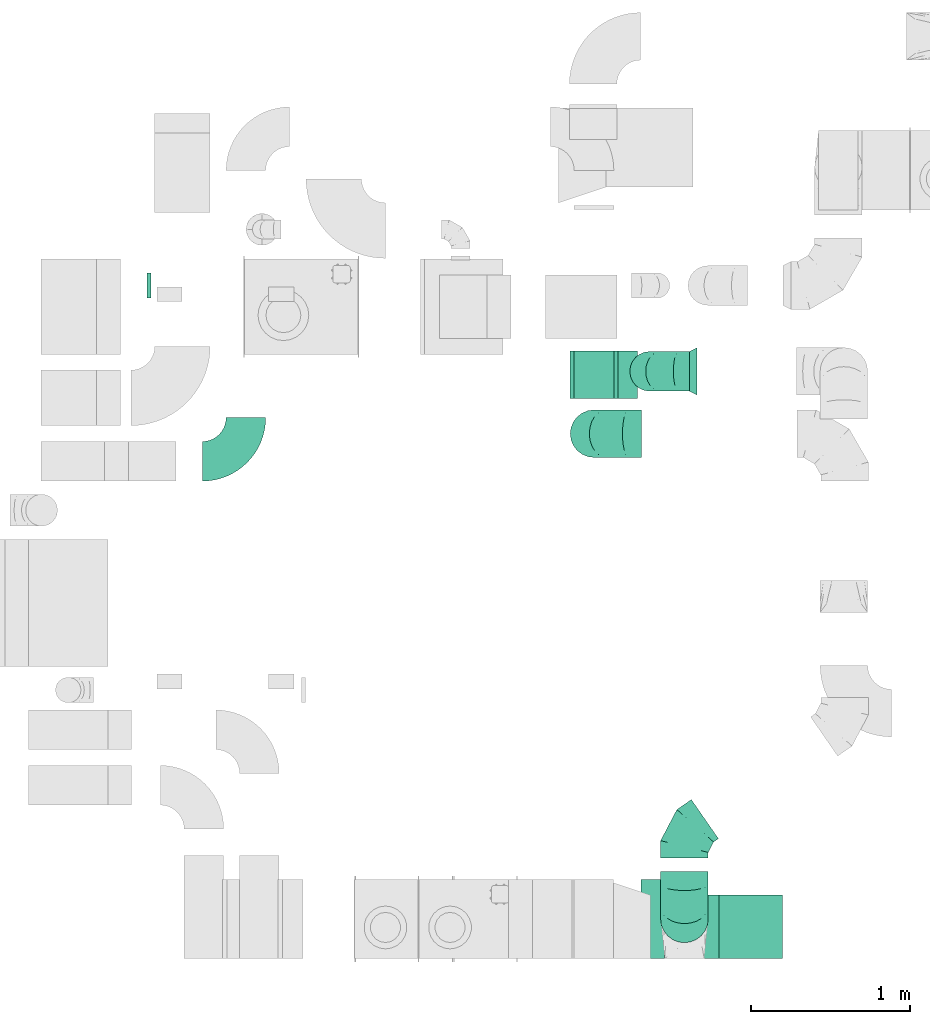
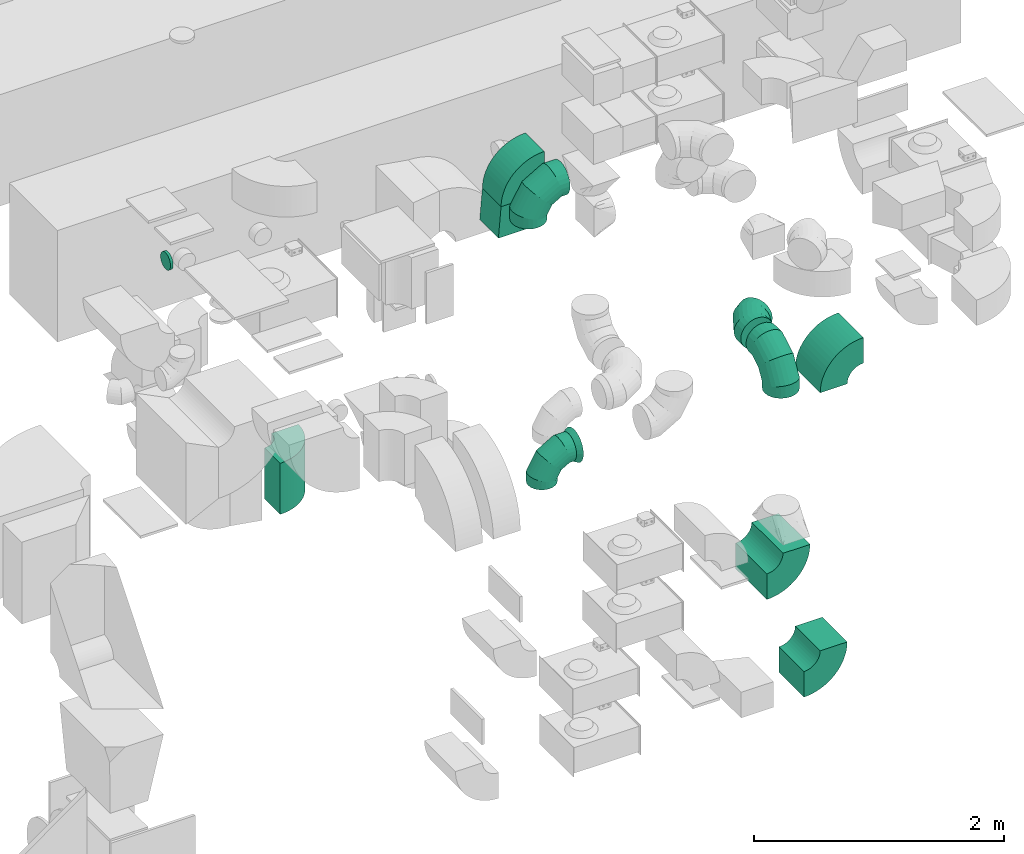
# One storey, part 9 of 59: 12 flow fittings.
"""IFC2X3 building model written with IfcOpenShell, lengths in millimetres."""

from ifc_helpers import new_model, entity, si_unit, converted_unit, derived_unit, direction, frame, frame_2d, origin, origin_2d_with_axis, place, context, subcontext, project, spatial, polyline, circle_curve, parameter, trimmed, segment, composite_curve, circle, outline, extrude, faceted_brep, source, transform, mapped, material, type_object, type_shapes, element, save


model = new_model("IFC2X3")

# Units and contexts
model_context = context("Model", 3, precision=0.01, world=origin(), true_north=direction((6.12303176911189e-17, 1.0)))
body_context = subcontext(model_context, "Body", "Model", "MODEL_VIEW")
ifc_project = project(units=[si_unit("LENGTHUNIT", "METRE", prefix="MILLI"), si_unit("AREAUNIT", "SQUARE_METRE"), si_unit("VOLUMEUNIT", "CUBIC_METRE"), converted_unit("PLANEANGLEUNIT", "DEGREE", entity("IfcRatioMeasure", 0.0174532925199433), si_unit("PLANEANGLEUNIT", "RADIAN"), dimensions=[0, 0, 0, 0, 0, 0, 0]), si_unit("MASSUNIT", "GRAM", prefix="KILO"), derived_unit("MASSDENSITYUNIT", [(si_unit("MASSUNIT", "GRAM", prefix="KILO"), 1), (si_unit("LENGTHUNIT", "METRE"), -3)]), derived_unit("MOMENTOFINERTIAUNIT", [(si_unit("LENGTHUNIT", "METRE"), 4)]), si_unit("TIMEUNIT", "SECOND"), si_unit("FREQUENCYUNIT", "HERTZ"), si_unit("THERMODYNAMICTEMPERATUREUNIT", "DEGREE_CELSIUS"), derived_unit("THERMALTRANSMITTANCEUNIT", [(si_unit("MASSUNIT", "GRAM", prefix="KILO"), 1), (si_unit("THERMODYNAMICTEMPERATUREUNIT", "KELVIN"), -1), (si_unit("TIMEUNIT", "SECOND"), -3)]), derived_unit("VOLUMETRICFLOWRATEUNIT", [(si_unit("LENGTHUNIT", "METRE"), 3), (si_unit("TIMEUNIT", "SECOND"), -1)]), derived_unit("MASSFLOWRATEUNIT", [(si_unit("MASSUNIT", "GRAM", prefix="KILO"), 1), (si_unit("TIMEUNIT", "SECOND"), -1)]), derived_unit("ROTATIONALFREQUENCYUNIT", [(si_unit("TIMEUNIT", "SECOND"), -1)]), si_unit("ELECTRICCURRENTUNIT", "AMPERE"), si_unit("ELECTRICVOLTAGEUNIT", "VOLT"), si_unit("POWERUNIT", "WATT"), si_unit("FORCEUNIT", "NEWTON", prefix="KILO"), si_unit("ILLUMINANCEUNIT", "LUX"), si_unit("LUMINOUSFLUXUNIT", "LUMEN"), si_unit("LUMINOUSINTENSITYUNIT", "CANDELA"), derived_unit("USERDEFINED", [(si_unit("MASSUNIT", "GRAM", prefix="KILO"), -1), (si_unit("LENGTHUNIT", "METRE"), -2), (si_unit("TIMEUNIT", "SECOND"), 3), (si_unit("LUMINOUSFLUXUNIT", "LUMEN"), 1)]), derived_unit("LINEARVELOCITYUNIT", [(si_unit("LENGTHUNIT", "METRE"), 1), (si_unit("TIMEUNIT", "SECOND"), -1)]), si_unit("PRESSUREUNIT", "PASCAL"), derived_unit("USERDEFINED", [(si_unit("LENGTHUNIT", "METRE"), -2), (si_unit("MASSUNIT", "GRAM", prefix="KILO"), 1), (si_unit("TIMEUNIT", "SECOND"), -2)]), derived_unit("LINEARFORCEUNIT", [(si_unit("MASSUNIT", "GRAM", prefix="KILO"), 1), (si_unit("LENGTHUNIT", "METRE"), 1), (si_unit("TIMEUNIT", "SECOND"), -2), (si_unit("LENGTHUNIT", "METRE"), -1)]), derived_unit("PLANARFORCEUNIT", [(si_unit("MASSUNIT", "GRAM", prefix="KILO"), 1), (si_unit("LENGTHUNIT", "METRE"), 1), (si_unit("TIMEUNIT", "SECOND"), -2), (si_unit("LENGTHUNIT", "METRE"), -2)])], contexts=[model_context])

# Site, building, storey
site_placement = place(None, origin())
site = spatial("IfcSite", under=ifc_project, at=site_placement, CompositionType="ELEMENT")
building_placement = place(site_placement, origin())
building = spatial("IfcBuilding", under=site, at=building_placement, CompositionType="ELEMENT")
storey_placement = place(building_placement, frame((0.0, 0.0, 28200.0)))
storey = spatial("IfcBuildingStorey", under=building, at=storey_placement, CompositionType="ELEMENT", Elevation=28200.0)

# Flow fittings
ifc_material = material()
duct_fitting_type_1 = type_object("IfcDuctFittingType", PredefinedType="NOTDEFINED", material=ifc_material)
shared_shape_1 = source(origin(), body_context, "Body", "SweptSolid", [
    extrude(circle(Radius=79.9999999999994, at=origin_2d_with_axis()), frame((0.0, 0.0, 0.0), z_axis=(1.0, 0.0, 0.0), x_axis=(0.0, 1.0, 0.0)), (0.0, 0.0, 1.0), 25.0000000000018),
])
type_shapes(duct_fitting_type_1, [shared_shape_1])
flow_fitting_1_placement = place(storey_placement, frame((28347.12, 12178.65, 3205.01), z_axis=(0.0, 0.0, 1.0), x_axis=(-1.0, 0.0, 0.0)))
element("IfcFlowFitting", 1, at=flow_fitting_1_placement, inside=storey, type_object=duct_fitting_type_1, material=ifc_material, context=body_context, shape_type="MappedRepresentation", body=[
    mapped(shared_shape_1, transform((0.0, 0.0, 0.0), scale=1.0)),
])
duct_fitting_type_2 = type_object("IfcDuctFittingType", PredefinedType="NOTDEFINED", material=ifc_material)
shared_shape_2 = source(origin(), body_context, "Body", "SweptSolid", [
    extrude(outline(polyline([(-125.0, -150.0), (125.0, -150.0), (150.0, 150.0), (-150.0, 150.0), (-125.0, -150.0)])), frame((150.0, -150.0, 0.0), z_axis=(0.0, 1.0, 0.0), x_axis=(0.0, 0.0, 1.0)), (0.0, 0.0, 1.0), 300.0),
])
type_shapes(duct_fitting_type_2, [shared_shape_2])
flow_fitting_2_placement = place(storey_placement, frame((31140.08, 11614.96, 3225.0), z_axis=(1.0, 0.0, 0.0), x_axis=(0.0, 0.0, -1.0)))
element("IfcFlowFitting", 2, at=flow_fitting_2_placement, inside=storey, type_object=duct_fitting_type_2, material=ifc_material, context=body_context, shape_type="MappedRepresentation", body=[
    mapped(shared_shape_2, transform((0.0, 0.0, 0.0), scale=1.0)),
])
duct_fitting_type_3 = type_object("IfcDuctFittingType", PredefinedType="NOTDEFINED", material=ifc_material)
shared_shape_3 = source(origin(), body_context, "Body", "Brep", [
    faceted_brep([(-250.0, 0.0, -125.0), (-250.0, -32.35, -120.74), (-250.0, -62.5, -108.25), (-250.0, -88.39, -88.39), (-250.0, -108.25, -62.5), (-250.0, -120.74, -32.35), (-250.0, -125.0, 0.0), (-250.0, -120.74, 32.35), (-250.0, -108.25, 62.5), (-250.0, -88.39, 88.39), (-250.0, -62.5, 108.25), (-250.0, -32.35, 120.74), (-250.0, 0.0, 125.0), (-250.0, 32.35, 120.74), (-250.0, 62.5, 108.25), (-250.0, 88.39, 88.39), (-250.0, 108.25, 62.5), (-250.0, 120.74, 32.35), (-250.0, 125.0, 0.0), (-250.0, 120.74, -32.35), (-250.0, 108.25, -62.5), (-250.0, 88.39, -88.39), (-250.0, 62.5, -108.25), (-250.0, 32.35, -120.74), (-191.68, 32.35, 120.74), (-199.76, 62.5, 108.25), (-183.01, 0.0, 125.0), (-206.7, 88.39, 88.39), (-215.37, 120.74, 32.35), (-216.51, 125.0, 0.0), (-212.02, 108.25, 62.5), (-212.02, 108.25, -62.5), (-206.7, 88.39, -88.39), (-215.37, 120.74, -32.35), (-191.68, 32.35, -120.74), (-183.01, 0.0, -125.0), (-199.76, 62.5, -108.25), (-174.34, -32.35, -120.74), (-166.27, -62.5, -108.25), (-159.33, -88.39, -88.39), (-154.01, -108.25, -62.5), (-150.66, -120.74, -32.35), (-149.52, -125.0, 0.0), (-150.66, -120.74, 32.35), (-154.01, -108.25, 62.5), (-159.33, -88.39, 88.39), (-166.27, -62.5, 108.25), (-174.34, -32.35, 120.74), (-90.67, 90.67, 120.74), (-112.74, 112.74, 108.25), (-66.99, 66.99, 125.0), (-131.69, 131.69, 88.39), (-146.23, 146.23, 62.5), (-155.38, 155.38, 32.35), (-158.49, 158.49, 0.0), (-155.38, 155.38, -32.35), (-146.23, 146.23, -62.5), (-131.69, 131.69, -88.39), (-90.67, 90.67, -120.74), (-66.99, 66.99, -125.0), (-112.74, 112.74, -108.25), (-43.3, 43.3, -120.74), (-21.23, 21.23, -108.25), (-2.28, 2.28, -88.39), (12.26, -12.26, -62.5), (21.4, -21.4, -32.35), (24.52, -24.52, 0.0), (21.4, -21.4, 32.35), (12.26, -12.26, 62.5), (-2.28, 2.28, 88.39), (-21.23, 21.23, 108.25), (-43.3, 43.3, 120.74), (-32.35, 191.68, 120.74), (-62.5, 199.76, 108.25), (0.0, 183.01, 125.0), (-88.39, 206.7, 88.39), (-108.25, 212.02, 62.5), (-120.74, 215.37, 32.35), (-125.0, 216.51, 0.0), (-120.74, 215.37, -32.35), (-108.25, 212.02, -62.5), (-88.39, 206.7, -88.39), (-32.35, 191.68, -120.74), (0.0, 183.01, -125.0), (-62.5, 199.76, -108.25), (32.35, 174.34, -120.74), (62.5, 166.27, -108.25), (88.39, 159.33, -88.39), (108.25, 154.01, -62.5), (120.74, 150.66, -32.35), (125.0, 149.52, 0.0), (120.74, 150.66, 32.35), (108.25, 154.01, 62.5), (88.39, 159.33, 88.39), (62.5, 166.27, 108.25), (32.35, 174.34, 120.74), (-32.35, 250.0, -120.74), (-62.5, 250.0, -108.25), (-88.39, 250.0, -88.39), (-108.25, 250.0, -62.5), (-120.74, 250.0, -32.35), (-125.0, 250.0, 0.0), (-120.74, 250.0, 32.35), (-108.25, 250.0, 62.5), (-88.39, 250.0, 88.39), (-62.5, 250.0, 108.25), (-32.35, 250.0, 120.74), (0.0, 250.0, 125.0), (32.35, 250.0, 120.74), (62.5, 250.0, 108.25), (88.39, 250.0, 88.39), (108.25, 250.0, 62.5), (120.74, 250.0, 32.35), (125.0, 250.0, 0.0), (120.74, 250.0, -32.35), (108.25, 250.0, -62.5), (88.39, 250.0, -88.39), (62.5, 250.0, -108.25), (32.35, 250.0, -120.74), (0.0, 250.0, -125.0)], [[[0, 1, 2, 3, 4, 5, 6, 7, 8, 9, 10, 11, 12, 13, 14, 15, 16, 17, 18, 19, 20, 21, 22, 23]], [[24, 25, 14, 13]], [[26, 24, 13, 12]], [[14, 25, 27, 15]], [[28, 29, 18, 17]], [[30, 28, 17, 16]], [[15, 27, 30, 16]], [[20, 31, 32, 21]], [[33, 31, 20, 19]], [[18, 29, 33, 19]], [[34, 35, 0, 23]], [[36, 34, 23, 22]], [[21, 32, 36, 22]], [[1, 0, 35, 37]], [[2, 1, 37, 38]], [[38, 39, 3, 2]], [[5, 4, 40, 41]], [[6, 5, 41, 42]], [[39, 40, 4, 3]], [[6, 42, 43, 7]], [[7, 43, 44, 8]], [[8, 44, 45, 9]], [[9, 45, 46, 10]], [[10, 46, 47, 11]], [[26, 12, 11, 47]], [[48, 49, 25, 24]], [[50, 48, 24, 26]], [[27, 25, 49, 51]], [[52, 53, 28, 30]], [[51, 52, 30, 27]], [[29, 28, 53, 54]], [[55, 56, 31, 33]], [[54, 55, 33, 29]], [[32, 31, 56, 57]], [[58, 59, 35, 34]], [[60, 58, 34, 36]], [[57, 60, 36, 32]], [[37, 35, 59, 61]], [[38, 37, 61, 62]], [[39, 38, 62, 63]], [[41, 40, 64, 65]], [[42, 41, 65, 66]], [[63, 64, 40, 39]], [[43, 42, 66, 67]], [[44, 43, 67, 68]], [[68, 69, 45, 44]], [[46, 45, 69, 70]], [[47, 46, 70, 71]], [[26, 47, 71, 50]], [[72, 73, 49, 48]], [[74, 72, 48, 50]], [[51, 49, 73, 75]], [[76, 77, 53, 52]], [[75, 76, 52, 51]], [[54, 53, 77, 78]], [[79, 80, 56, 55]], [[78, 79, 55, 54]], [[57, 56, 80, 81]], [[82, 83, 59, 58]], [[84, 82, 58, 60]], [[81, 84, 60, 57]], [[61, 59, 83, 85]], [[62, 61, 85, 86]], [[63, 62, 86, 87]], [[65, 64, 88, 89]], [[66, 65, 89, 90]], [[87, 88, 64, 63]], [[67, 66, 90, 91]], [[68, 67, 91, 92]], [[92, 93, 69, 68]], [[70, 69, 93, 94]], [[71, 70, 94, 95]], [[50, 71, 95, 74]], [[96, 97, 98, 99, 100, 101, 102, 103, 104, 105, 106, 107, 108, 109, 110, 111, 112, 113, 114, 115, 116, 117, 118, 119]], [[72, 74, 107, 106]], [[73, 72, 106, 105]], [[75, 73, 105, 104]], [[77, 76, 103, 102]], [[78, 77, 102, 101]], [[75, 104, 103, 76]], [[78, 101, 100, 79]], [[79, 100, 99, 80]], [[80, 99, 98, 81]], [[84, 97, 96, 82]], [[82, 96, 119, 83]], [[84, 81, 98, 97]], [[83, 119, 118, 85]], [[85, 118, 117, 86]], [[116, 87, 86, 117]], [[88, 115, 114, 89]], [[89, 114, 113, 90]], [[115, 88, 87, 116]], [[91, 90, 113, 112]], [[92, 91, 112, 111]], [[111, 110, 93, 92]], [[95, 94, 109, 108]], [[74, 95, 108, 107]], [[110, 109, 94, 93]]]),
])
type_shapes(duct_fitting_type_3, [shared_shape_3])
flow_fitting_3_placement = place(storey_placement, frame((31490.77, 11637.41, 520.0), z_axis=(0.0, -1.0, 0.0), x_axis=(-1.0, 0.0, 0.0)))
element("IfcFlowFitting", 3, at=flow_fitting_3_placement, inside=storey, type_object=duct_fitting_type_3, material=ifc_material, context=body_context, shape_type="MappedRepresentation", body=[
    mapped(shared_shape_3, transform((0.0, 0.0, 0.0), scale=1.0)),
])
duct_fitting_type_4 = type_object("IfcDuctFittingType", PredefinedType="NOTDEFINED", material=ifc_material)
shared_shape_4 = source(origin(), body_context, "Body", "Brep", [
    faceted_brep([(-300.0, 0.0, -150.0), (-300.0, -38.82, -144.89), (-300.0, -75.0, -129.9), (-300.0, -106.07, -106.07), (-300.0, -129.9, -75.0), (-300.0, -144.89, -38.82), (-300.0, -150.0, 0.0), (-300.0, -144.89, 38.82), (-300.0, -129.9, 75.0), (-300.0, -106.07, 106.07), (-300.0, -75.0, 129.9), (-300.0, -38.82, 144.89), (-300.0, 0.0, 150.0), (-300.0, 38.82, 144.89), (-300.0, 75.0, 129.9), (-300.0, 106.07, 106.07), (-300.0, 129.9, 75.0), (-300.0, 144.89, 38.82), (-300.0, 150.0, 0.0), (-300.0, 144.89, -38.82), (-300.0, 129.9, -75.0), (-300.0, 106.07, -106.07), (-300.0, 75.0, -129.9), (-300.0, 38.82, -144.89), (-230.02, 38.82, 144.89), (-239.71, 75.0, 129.9), (-219.62, 0.0, 150.0), (-248.04, 106.07, 106.07), (-258.44, 144.89, 38.82), (-259.81, 150.0, 0.0), (-254.42, 129.9, 75.0), (-254.42, 129.9, -75.0), (-248.04, 106.07, -106.07), (-258.44, 144.89, -38.82), (-230.02, 38.82, -144.89), (-219.62, 0.0, -150.0), (-239.71, 75.0, -129.9), (-209.21, -38.82, -144.89), (-199.52, -75.0, -129.9), (-191.19, -106.07, -106.07), (-184.81, -129.9, -75.0), (-180.79, -144.89, -38.82), (-179.42, -150.0, 0.0), (-180.79, -144.89, 38.82), (-184.81, -129.9, 75.0), (-191.19, -106.07, 106.07), (-199.52, -75.0, 129.9), (-209.21, -38.82, 144.89), (-108.81, 108.81, 144.89), (-135.29, 135.29, 129.9), (-80.38, 80.38, 150.0), (-158.03, 158.03, 106.07), (-175.48, 175.48, 75.0), (-186.45, 186.45, 38.82), (-190.19, 190.19, 0.0), (-186.45, 186.45, -38.82), (-175.48, 175.48, -75.0), (-158.03, 158.03, -106.07), (-108.81, 108.81, -144.89), (-80.38, 80.38, -150.0), (-135.29, 135.29, -129.9), (-51.96, 51.96, -144.89), (-25.48, 25.48, -129.9), (-2.74, 2.74, -106.07), (14.71, -14.71, -75.0), (25.68, -25.68, -38.82), (29.42, -29.42, 0.0), (25.68, -25.68, 38.82), (14.71, -14.71, 75.0), (-2.74, 2.74, 106.07), (-25.48, 25.48, 129.9), (-51.96, 51.96, 144.89), (-38.82, 230.02, 144.89), (-75.0, 239.71, 129.9), (0.0, 219.62, 150.0), (-106.07, 248.04, 106.07), (-129.9, 254.42, 75.0), (-144.89, 258.44, 38.82), (-150.0, 259.81, 0.0), (-144.89, 258.44, -38.82), (-129.9, 254.42, -75.0), (-106.07, 248.04, -106.07), (-38.82, 230.02, -144.89), (0.0, 219.62, -150.0), (-75.0, 239.71, -129.9), (38.82, 209.21, -144.89), (75.0, 199.52, -129.9), (106.07, 191.19, -106.07), (129.9, 184.81, -75.0), (144.89, 180.79, -38.82), (150.0, 179.42, 0.0), (144.89, 180.79, 38.82), (129.9, 184.81, 75.0), (106.07, 191.19, 106.07), (75.0, 199.52, 129.9), (38.82, 209.21, 144.89), (-150.0, 300.0, 0.0), (-144.89, 300.0, 38.82), (-129.9, 300.0, 75.0), (-106.07, 300.0, 106.07), (-75.0, 300.0, 129.9), (-38.82, 300.0, 144.89), (0.0, 300.0, 150.0), (38.82, 300.0, 144.89), (75.0, 300.0, 129.9), (106.07, 300.0, 106.07), (129.9, 300.0, 75.0), (144.89, 300.0, 38.82), (150.0, 300.0, 0.0), (144.89, 300.0, -38.82), (129.9, 300.0, -75.0), (106.07, 300.0, -106.07), (75.0, 300.0, -129.9), (38.82, 300.0, -144.89), (0.0, 300.0, -150.0), (-38.82, 300.0, -144.89), (-75.0, 300.0, -129.9), (-106.07, 300.0, -106.07), (-129.9, 300.0, -75.0), (-144.89, 300.0, -38.82)], [[[0, 1, 2, 3, 4, 5, 6, 7, 8, 9, 10, 11, 12, 13, 14, 15, 16, 17, 18, 19, 20, 21, 22, 23]], [[24, 25, 14, 13]], [[26, 24, 13, 12]], [[14, 25, 27, 15]], [[28, 29, 18, 17]], [[30, 28, 17, 16]], [[15, 27, 30, 16]], [[20, 31, 32, 21]], [[33, 31, 20, 19]], [[18, 29, 33, 19]], [[34, 35, 0, 23]], [[36, 34, 23, 22]], [[32, 36, 22, 21]], [[1, 0, 35, 37]], [[2, 1, 37, 38]], [[38, 39, 3, 2]], [[5, 4, 40, 41]], [[6, 5, 41, 42]], [[39, 40, 4, 3]], [[6, 42, 43, 7]], [[7, 43, 44, 8]], [[8, 44, 45, 9]], [[9, 45, 46, 10]], [[10, 46, 47, 11]], [[26, 12, 11, 47]], [[48, 49, 25, 24]], [[50, 48, 24, 26]], [[27, 25, 49, 51]], [[52, 53, 28, 30]], [[51, 52, 30, 27]], [[29, 28, 53, 54]], [[55, 56, 31, 33]], [[54, 55, 33, 29]], [[32, 31, 56, 57]], [[58, 59, 35, 34]], [[60, 58, 34, 36]], [[57, 60, 36, 32]], [[37, 35, 59, 61]], [[38, 37, 61, 62]], [[39, 38, 62, 63]], [[41, 40, 64, 65]], [[42, 41, 65, 66]], [[63, 64, 40, 39]], [[43, 42, 66, 67]], [[44, 43, 67, 68]], [[68, 69, 45, 44]], [[46, 45, 69, 70]], [[47, 46, 70, 71]], [[26, 47, 71, 50]], [[72, 73, 49, 48]], [[74, 72, 48, 50]], [[51, 49, 73, 75]], [[76, 77, 53, 52]], [[75, 76, 52, 51]], [[54, 53, 77, 78]], [[79, 80, 56, 55]], [[78, 79, 55, 54]], [[57, 56, 80, 81]], [[82, 83, 59, 58]], [[84, 82, 58, 60]], [[81, 84, 60, 57]], [[61, 59, 83, 85]], [[62, 61, 85, 86]], [[63, 62, 86, 87]], [[65, 64, 88, 89]], [[66, 65, 89, 90]], [[87, 88, 64, 63]], [[67, 66, 90, 91]], [[68, 67, 91, 92]], [[92, 93, 69, 68]], [[70, 69, 93, 94]], [[71, 70, 94, 95]], [[50, 71, 95, 74]], [[96, 97, 98, 99, 100, 101, 102, 103, 104, 105, 106, 107, 108, 109, 110, 111, 112, 113, 114, 115, 116, 117, 118, 119]], [[101, 100, 73, 72]], [[102, 101, 72, 74]], [[75, 73, 100, 99]], [[77, 76, 98, 97]], [[78, 77, 97, 96]], [[99, 98, 76, 75]], [[119, 118, 80, 79]], [[96, 119, 79, 78]], [[117, 81, 80, 118]], [[84, 116, 115, 82]], [[82, 115, 114, 83]], [[116, 84, 81, 117]], [[83, 114, 113, 85]], [[85, 113, 112, 86]], [[111, 87, 86, 112]], [[88, 110, 109, 89]], [[89, 109, 108, 90]], [[110, 88, 87, 111]], [[91, 90, 108, 107]], [[92, 91, 107, 106]], [[106, 105, 93, 92]], [[95, 94, 104, 103]], [[74, 95, 103, 102]], [[105, 104, 94, 93]]]),
])
type_shapes(duct_fitting_type_4, [shared_shape_4])
for number, where, z_axis, x_axis in (
    (4, (31710.0, 8184.5, 3500.0), (-1.0, 0.0, 0.0), (0.0, 0.0, 1.0)),
    (5, (31140.0, 11244.5, 3500.0), (0.0, -1.0, 0.0), (-1.0, 0.0, 0.0)),
):
    element("IfcFlowFitting", number, at=place(storey_placement, frame(where, z_axis=z_axis, x_axis=x_axis)), inside=storey, type_object=duct_fitting_type_4, material=ifc_material, context=body_context, shape_type="MappedRepresentation", body=[
        mapped(shared_shape_4, transform((0.0, 0.0, 0.0), scale=1.0)),
    ])
duct_fitting_type_5 = type_object("IfcDuctFittingType", PredefinedType="NOTDEFINED", material=ifc_material)
shared_shape_5 = source(origin(), body_context, "Body", "Brep", [
    faceted_brep([(50.0, 101.13, -73.47), (50.0, 118.88, -38.63), (50.0, 125.0, 0.0), (50.0, 118.88, 38.63), (50.0, 101.13, 73.47), (50.0, 73.47, 101.13), (50.0, 38.63, 118.88), (50.0, 0.0, 125.0), (50.0, -38.63, 118.88), (50.0, -73.47, 101.13), (50.0, -101.13, 73.47), (50.0, -118.88, 38.63), (50.0, -125.0, 0.0), (50.0, -118.88, -38.63), (50.0, -101.13, -73.47), (50.0, -73.47, -101.13), (50.0, -38.63, -118.88), (50.0, 0.0, -125.0), (50.0, 38.63, -118.88), (50.0, 73.47, -101.13), (0.0, -150.0, 0.0), (0.0, -144.89, 38.82), (0.0, -129.9, 75.0), (0.0, -106.07, 106.07), (0.0, -75.0, 129.9), (0.0, -38.82, 144.89), (0.0, 0.0, 150.0), (0.0, 38.82, 144.89), (0.0, 75.0, 129.9), (0.0, 106.07, 106.07), (0.0, 129.9, 75.0), (0.0, 144.89, 38.82), (0.0, 150.0, 0.0), (0.0, 144.89, -38.82), (0.0, 129.9, -75.0), (0.0, 106.07, -106.07), (0.0, 75.0, -129.9), (0.0, 38.82, -144.89), (0.0, 0.0, -150.0), (0.0, -38.82, -144.89), (0.0, -75.0, -129.9), (0.0, -106.07, -106.07), (0.0, -129.9, -75.0), (0.0, -144.89, -38.82)], [[[0, 1, 2, 3, 4, 5, 6, 7, 8, 9, 10, 11, 12, 13, 14, 15, 16, 17, 18, 19]], [[20, 21, 22, 23, 24, 25, 26, 27, 28, 29, 30, 31, 32, 33, 34, 35, 36, 37, 38, 39, 40, 41, 42, 43]], [[27, 7, 6]], [[28, 6, 5]], [[27, 26, 7]], [[28, 27, 6]], [[5, 29, 28]], [[3, 2, 31]], [[4, 3, 30]], [[30, 29, 4]], [[31, 30, 3]], [[2, 32, 31]], [[4, 29, 5]], [[21, 12, 11]], [[22, 11, 10]], [[21, 20, 12]], [[22, 21, 11]], [[10, 23, 22]], [[8, 7, 25]], [[9, 8, 24]], [[24, 23, 9]], [[25, 24, 8]], [[7, 26, 25]], [[9, 23, 10]], [[39, 17, 16]], [[40, 16, 15]], [[39, 38, 17]], [[40, 39, 16]], [[15, 41, 40]], [[13, 12, 43]], [[14, 13, 42]], [[42, 41, 14]], [[43, 42, 13]], [[12, 20, 43]], [[14, 41, 15]], [[33, 2, 1]], [[34, 1, 0]], [[33, 32, 2]], [[34, 33, 1]], [[0, 35, 34]], [[18, 17, 37]], [[19, 18, 36]], [[36, 35, 19]], [[37, 36, 18]], [[17, 38, 37]], [[19, 35, 0]]]),
])
type_shapes(duct_fitting_type_5, [shared_shape_5])
flow_fitting_4_placement = place(storey_placement, frame((31790.77, 11637.41, 520.0), z_axis=(0.0, 0.0, 1.0), x_axis=(-1.0, 0.0, 0.0)))
element("IfcFlowFitting", 6, at=flow_fitting_4_placement, inside=storey, type_object=duct_fitting_type_5, material=ifc_material, context=body_context, shape_type="MappedRepresentation", body=[
    mapped(shared_shape_5, transform((0.0, 0.0, 0.0), scale=1.0)),
])
duct_fitting_type_6 = type_object("IfcDuctFittingType", PredefinedType="NOTDEFINED", material=ifc_material)
shared_shape_6 = source(origin(), body_context, "Body", "Brep", [
    faceted_brep([(-157.09, 0.0, -150.0), (-157.09, -38.82, -144.89), (-157.09, -75.0, -129.9), (-157.09, -106.07, -106.07), (-157.09, -129.9, -75.0), (-157.09, -144.89, -38.82), (-157.09, -150.0, 0.0), (-157.09, -144.89, 38.82), (-157.09, -129.9, 75.0), (-157.09, -106.07, 106.07), (-157.09, -75.0, 129.9), (-157.09, -38.82, 144.89), (-157.09, 0.0, 150.0), (-157.09, 38.82, 144.89), (-157.09, 75.0, 129.9), (-157.09, 106.07, 106.07), (-157.09, 129.9, 75.0), (-157.09, 144.89, 38.82), (-157.09, 150.0, 0.0), (-157.09, 144.89, -38.82), (-157.09, 129.9, -75.0), (-157.09, 106.07, -106.07), (-157.09, 75.0, -129.9), (-157.09, 38.82, -144.89), (-92.85, 38.82, 144.89), (-101.74, 75.0, 129.9), (-83.3, 0.0, 150.0), (-109.39, 106.07, 106.07), (-115.25, 129.9, 75.0), (-118.93, 144.89, 38.82), (-120.19, 150.0, 0.0), (-118.93, 144.89, -38.82), (-115.25, 129.9, -75.0), (-109.39, 106.07, -106.07), (-92.85, 38.82, -144.89), (-83.3, 0.0, -150.0), (-101.74, 75.0, -129.9), (-73.75, -38.82, -144.89), (-64.85, -75.0, -129.9), (-57.21, -106.07, -106.07), (-51.34, -129.9, -75.0), (-47.66, -144.89, -38.82), (-46.4, -150.0, 0.0), (-47.66, -144.89, 38.82), (-51.34, -129.9, 75.0), (-57.21, -106.07, 106.07), (-64.85, -75.0, 129.9), (-73.75, -38.82, 144.89), (20.98, 98.42, 144.89), (-3.69, 126.35, 129.9), (47.45, 68.46, 150.0), (-24.87, 150.32, 106.07), (-41.12, 168.72, 75.0), (-51.34, 180.29, 38.82), (-54.82, 184.23, 0.0), (-51.34, 180.29, -38.82), (-41.12, 168.72, -75.0), (-24.87, 150.32, -106.07), (20.98, 98.42, -144.89), (47.45, 68.46, -150.0), (-3.69, 126.35, -129.9), (73.92, 38.5, -144.89), (98.58, 10.58, -129.9), (119.76, -13.4, -106.07), (136.01, -31.8, -75.0), (146.23, -43.36, -38.82), (149.72, -47.31, 0.0), (146.23, -43.36, 38.82), (136.01, -31.8, 75.0), (119.76, -13.4, 106.07), (98.58, 10.58, 129.9), (73.92, 38.5, 144.89), (89.48, 129.11, 150.0), (57.57, 151.22, 144.89), (27.84, 171.83, 129.9), (2.31, 189.53, 106.07), (-17.29, 203.11, 75.0), (-29.6, 211.64, 38.82), (-33.8, 214.56, 0.0), (-29.6, 211.64, -38.82), (-17.29, 203.11, -75.0), (2.31, 189.53, -106.07), (27.84, 171.83, -129.9), (57.57, 151.22, -144.89), (89.48, 129.11, -150.0), (121.39, 107.0, -144.89), (151.12, 86.39, -129.9), (176.66, 68.69, -106.07), (196.25, 55.11, -75.0), (208.57, 46.58, -38.82), (212.77, 43.67, 0.0), (208.57, 46.58, 38.82), (196.25, 55.11, 75.0), (176.66, 68.69, 106.07), (151.12, 86.39, 129.9), (121.39, 107.0, 144.89)], [[[0, 1, 2, 3, 4, 5, 6, 7, 8, 9, 10, 11, 12, 13, 14, 15, 16, 17, 18, 19, 20, 21, 22, 23]], [[24, 25, 14, 13]], [[26, 24, 13, 12]], [[27, 15, 14, 25]], [[28, 29, 17, 16]], [[28, 16, 15, 27]], [[30, 18, 17, 29]], [[31, 32, 20, 19]], [[30, 31, 19, 18]], [[21, 20, 32, 33]], [[34, 35, 0, 23]], [[36, 34, 23, 22]], [[33, 36, 22, 21]], [[1, 0, 35, 37]], [[2, 1, 37, 38]], [[38, 39, 3, 2]], [[5, 4, 40, 41]], [[6, 5, 41, 42]], [[39, 40, 4, 3]], [[6, 42, 43, 7]], [[7, 43, 44, 8]], [[8, 44, 45, 9]], [[9, 45, 46, 10]], [[10, 46, 47, 11]], [[26, 12, 11, 47]], [[48, 49, 25, 24]], [[50, 48, 24, 26]], [[27, 25, 49, 51]], [[52, 53, 29, 28]], [[51, 52, 28, 27]], [[30, 29, 53, 54]], [[55, 56, 32, 31]], [[54, 55, 31, 30]], [[33, 32, 56, 57]], [[58, 59, 35, 34]], [[60, 58, 34, 36]], [[57, 60, 36, 33]], [[37, 35, 59, 61]], [[38, 37, 61, 62]], [[39, 38, 62, 63]], [[41, 40, 64, 65]], [[42, 41, 65, 66]], [[63, 64, 40, 39]], [[43, 42, 66, 67]], [[44, 43, 67, 68]], [[68, 69, 45, 44]], [[46, 45, 69, 70]], [[47, 46, 70, 71]], [[26, 47, 71, 50]], [[48, 50, 72, 73]], [[49, 48, 73, 74]], [[51, 49, 74, 75]], [[53, 52, 76, 77]], [[54, 53, 77, 78]], [[51, 75, 76, 52]], [[54, 78, 79, 55]], [[55, 79, 80, 56]], [[56, 80, 81, 57]], [[60, 82, 83, 58]], [[58, 83, 84, 59]], [[60, 57, 81, 82]], [[59, 84, 85, 61]], [[61, 85, 86, 62]], [[87, 63, 62, 86]], [[64, 88, 89, 65]], [[65, 89, 90, 66]], [[88, 64, 63, 87]], [[67, 66, 90, 91]], [[68, 67, 91, 92]], [[92, 93, 69, 68]], [[71, 70, 94, 95]], [[50, 71, 95, 72]], [[93, 94, 70, 69]], [[78, 77, 76, 75, 74, 73, 72, 95, 94, 93, 92, 91, 90, 89, 88, 87, 86, 85, 84, 83, 82, 81, 80, 79]]]),
])
type_shapes(duct_fitting_type_6, [shared_shape_6])
flow_fitting_5_placement = place(storey_placement, frame((31710.0, 8724.5, 3500.0), z_axis=(0.0, 0.0, 1.0), x_axis=(-0.821899128606522, -0.569633059430227, 0.0)))
element("IfcFlowFitting", 7, at=flow_fitting_5_placement, inside=storey, type_object=duct_fitting_type_6, material=ifc_material, context=body_context, shape_type="MappedRepresentation", body=[
    mapped(shared_shape_6, transform((0.0, 0.0, 0.0), scale=1.0)),
])
duct_fitting_type_7 = type_object("IfcDuctFittingType", PredefinedType="NOTDEFINED", material=ifc_material)
shared_shape_7 = source(origin(), body_context, "Body", "SweptSolid", [
    extrude(outline(composite_curve([segment(polyline([(-262.5, -137.5), (-12.5, -137.5)]), True, "CONTINUOUS"), segment(trimmed(circle_curve(frame_2d((137.5, -137.5), x_axis=(0.0, 1.0)), 150.0), [parameter(0.0)], [parameter(90.0000000000001)], True, "PARAMETER"), False, "CONTINUOUS"), segment(polyline([(137.5, 12.5), (137.5, 262.5)]), True, "CONTINUOUS"), segment(trimmed(circle_curve(frame_2d((137.5, -137.5), x_axis=(0.0, 1.0)), 400.0), [parameter(0.0)], [parameter(90.0000000000001)], True, "PARAMETER"), True, "CONTINUOUS")], self_intersect=False)), frame((-137.5, 137.5, -250.0), z_axis=(0.0, 0.0, 1.0), x_axis=(-1.0, 0.0, 0.0)), (0.0, 0.0, 1.0), 500.0),
])
type_shapes(duct_fitting_type_7, [shared_shape_7])
flow_fitting_6_placement = place(storey_placement, frame((28945.03, 11070.06, 1600.01)))
element("IfcFlowFitting", 8, at=flow_fitting_6_placement, inside=storey, type_object=duct_fitting_type_7, material=ifc_material, context=body_context, shape_type="MappedRepresentation", body=[
    mapped(shared_shape_7, transform((0.0, 0.0, 0.0), scale=1.0)),
])
flow_fitting_7_placement = place(storey_placement, frame((31710.0, 8184.5, 1500.0), z_axis=(0.0, -1.0, 0.0), x_axis=(1.0, 0.0, 0.0)))
element("IfcFlowFitting", 9, at=flow_fitting_7_placement, inside=storey, type_object=duct_fitting_type_7, material=ifc_material, context=body_context, shape_type="MappedRepresentation", body=[
    mapped(shared_shape_7, transform((0.0, 0.0, 0.0), scale=1.0)),
])
duct_fitting_type_8 = type_object("IfcDuctFittingType", PredefinedType="NOTDEFINED", material=ifc_material)
shared_shape_8 = source(origin(), body_context, "Body", "SweptSolid", [
    extrude(outline(composite_curve([segment(polyline([(-262.5, -137.5), (-12.5, -137.5)]), True, "CONTINUOUS"), segment(trimmed(circle_curve(frame_2d((137.5, -137.5), x_axis=(0.0, 1.0)), 150.0), [parameter(0.0)], [parameter(90.0000000000001)], True, "PARAMETER"), False, "CONTINUOUS"), segment(polyline([(137.5, 12.5), (137.5, 262.5)]), True, "CONTINUOUS"), segment(trimmed(circle_curve(frame_2d((137.5, -137.5), x_axis=(0.0, 1.0)), 400.0), [parameter(0.0)], [parameter(90.0000000000001)], True, "PARAMETER"), True, "CONTINUOUS")], self_intersect=False)), frame((-137.5, 137.5, -150.0), z_axis=(0.0, 0.0, 1.0), x_axis=(-1.0, 0.0, 0.0)), (0.0, 0.0, 1.0), 300.0),
])
type_shapes(duct_fitting_type_8, [shared_shape_8])
flow_fitting_8_placement = place(storey_placement, frame((31140.08, 11614.96, 3500.0), z_axis=(0.0, -1.0, 0.0), x_axis=(-1.0, 0.0, 0.0)))
element("IfcFlowFitting", 10, at=flow_fitting_8_placement, inside=storey, type_object=duct_fitting_type_8, material=ifc_material, context=body_context, shape_type="MappedRepresentation", body=[
    mapped(shared_shape_8, transform((0.0, 0.0, 0.0), scale=1.0)),
])
duct_fitting_type_9 = type_object("IfcDuctFittingType", PredefinedType="NOTDEFINED", material=ifc_material)
shared_shape_9 = source(origin(), body_context, "Body", "SweptSolid", [
    extrude(outline(composite_curve([segment(polyline([(-262.5, -137.5), (-12.5, -137.5)]), True, "CONTINUOUS"), segment(trimmed(circle_curve(frame_2d((137.5, -137.5), x_axis=(-3.34916876454372e-08, 1.0)), 150.0), [parameter(0.0)], [parameter(89.9999980810677)], True, "PARAMETER"), False, "CONTINUOUS"), segment(polyline([(137.5, 12.5), (137.5, 262.5)]), True, "CONTINUOUS"), segment(trimmed(circle_curve(frame_2d((137.5, -137.5), x_axis=(-3.34916876454372e-08, 1.0)), 400.0), [parameter(0.0)], [parameter(89.9999980810677)], True, "PARAMETER"), True, "CONTINUOUS")], self_intersect=False)), frame((-137.5, 137.5, -200.0), z_axis=(0.0, 0.0, 1.0), x_axis=(-1.0, 3.34916872006374e-08, 0.0)), (0.0, 0.0, 1.0), 400.0),
])
type_shapes(duct_fitting_type_9, [shared_shape_9])
flow_fitting_9_placement = place(storey_placement, frame((32054.5, 8134.51, 3500.0), z_axis=(0.0, -1.0, 0.0), x_axis=(-1.0, 0.0, -3.3491687190218e-08)))
element("IfcFlowFitting", 11, at=flow_fitting_9_placement, inside=storey, type_object=duct_fitting_type_9, material=ifc_material, context=body_context, shape_type="MappedRepresentation", body=[
    mapped(shared_shape_9, transform((0.0, 0.0, 0.0), scale=1.0)),
])
duct_fitting_type_10 = type_object("IfcDuctFittingType", PredefinedType="NOTDEFINED", material=ifc_material)
shared_shape_10 = source(origin(), body_context, "Body", "SweptSolid", [
    extrude(outline(composite_curve([segment(polyline([(-262.5, -137.5), (-12.5, -137.5)]), True, "CONTINUOUS"), segment(trimmed(circle_curve(frame_2d((137.5, -137.5), x_axis=(0.0, 1.0)), 150.0), [parameter(0.0)], [parameter(90.0000000000001)], True, "PARAMETER"), False, "CONTINUOUS"), segment(polyline([(137.5, 12.5), (137.5, 262.5)]), True, "CONTINUOUS"), segment(trimmed(circle_curve(frame_2d((137.5, -137.5), x_axis=(0.0, 1.0)), 400.0), [parameter(0.0)], [parameter(90.0000000000001)], True, "PARAMETER"), True, "CONTINUOUS")], self_intersect=False)), frame((-137.5, 137.5, -200.0), z_axis=(0.0, 0.0, 1.0), x_axis=(-1.0, 0.0, 0.0)), (0.0, 0.0, 1.0), 400.0),
])
type_shapes(duct_fitting_type_10, [shared_shape_10])
flow_fitting_10_placement = place(storey_placement, frame((32054.5, 8134.51, 425.0), z_axis=(0.0, -1.0, 0.0), x_axis=(1.0, 0.0, 0.0)))
element("IfcFlowFitting", 12, at=flow_fitting_10_placement, inside=storey, type_object=duct_fitting_type_10, material=ifc_material, context=body_context, shape_type="MappedRepresentation", body=[
    mapped(shared_shape_10, transform((0.0, 0.0, 0.0), scale=1.0)),
])

save(model, "model.ifc")
